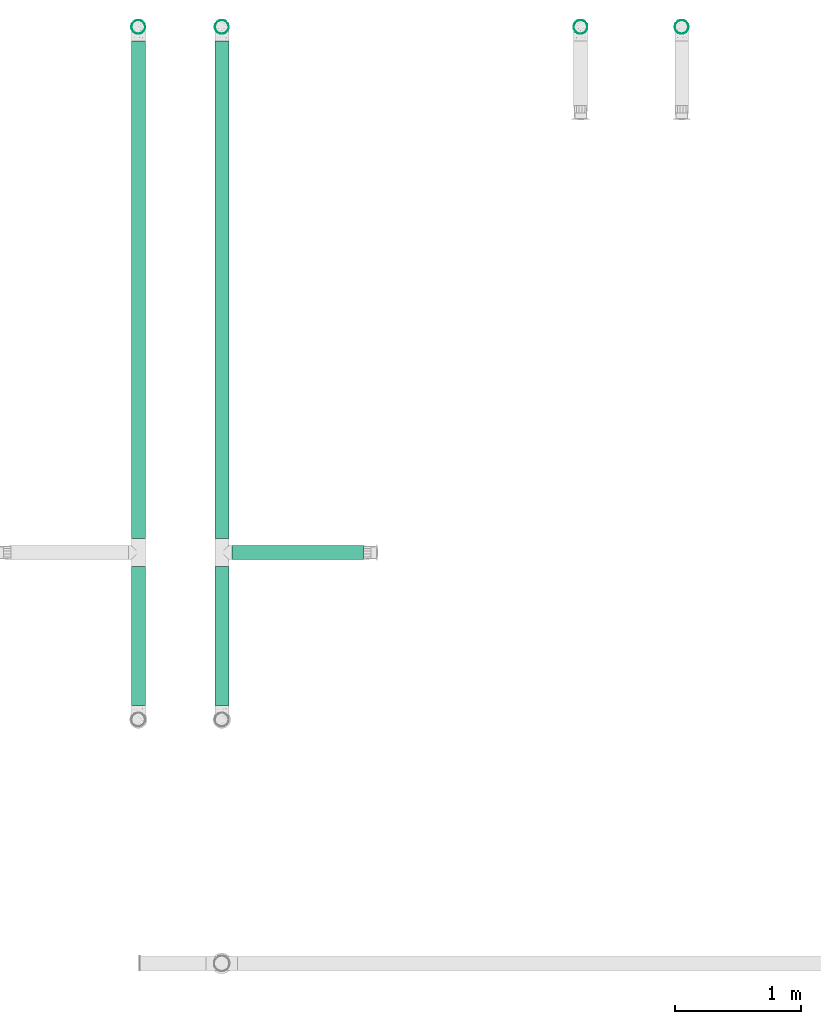
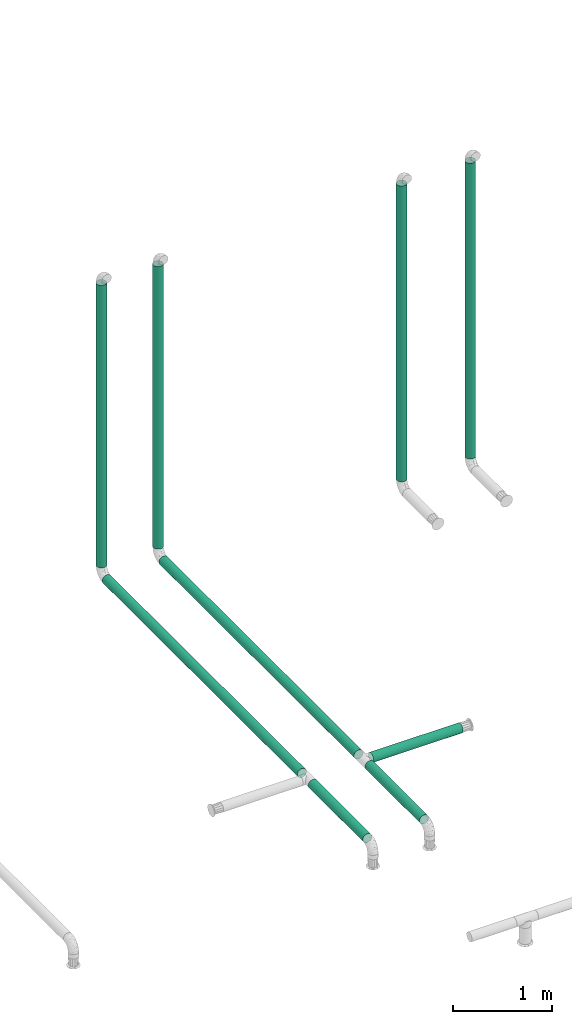
# One storey, part 4 of 115: 9 flow segments.
"""IFC2X3 building model written with IfcOpenShell, lengths in millimetres."""

from ifc_helpers import new_model, entity, si_unit, converted_unit, derived_unit, direction, frame, origin_with_axes, origin_2d_with_axis, place, context, subcontext, project, spatial, hollow_circle, extrude, source, transform, mapped, material, layer, layer_set, layer_usage, type_object, element, save


model = new_model("IFC2X3")

# Units and contexts
model_context = context("Model", 3, precision=1e-05, world=origin_with_axes(), true_north=direction((0.0, 1.0)))
body_context = subcontext(model_context, "Body", "Model", "MODEL_VIEW")
ifc_project = project(units=[si_unit("AREAUNIT", "SQUARE_METRE"), si_unit("VOLUMEUNIT", "CUBIC_METRE", prefix="DECI"), si_unit("TIMEUNIT", "SECOND"), si_unit("THERMODYNAMICTEMPERATUREUNIT", "DEGREE_CELSIUS"), si_unit("PRESSUREUNIT", "PASCAL"), si_unit("MASSUNIT", "GRAM", prefix="KILO"), si_unit("LENGTHUNIT", "METRE", prefix="MILLI"), si_unit("POWERUNIT", "WATT"), si_unit("ELECTRICCURRENTUNIT", "AMPERE"), si_unit("ELECTRICVOLTAGEUNIT", "VOLT"), derived_unit("VOLUMETRICFLOWRATEUNIT", [(si_unit("VOLUMEUNIT", "CUBIC_METRE", prefix="DECI"), 1), (si_unit("TIMEUNIT", "SECOND"), -1)]), derived_unit("LINEARVELOCITYUNIT", [(si_unit("LENGTHUNIT", "METRE"), 1), (si_unit("TIMEUNIT", "SECOND"), -1)]), derived_unit("MASSDENSITYUNIT", [(si_unit("MASSUNIT", "GRAM", prefix="KILO"), 1), (si_unit("VOLUMEUNIT", "CUBIC_METRE"), -1)]), converted_unit("PLANEANGLEUNIT", "DEGREE", entity("IfcRatioMeasure", 0.01745), si_unit("PLANEANGLEUNIT", "RADIAN"), dimensions=[0, 0, 0, 0, 0, 0, 0])], contexts=[model_context])

# Site, building, storey
site_placement = place(None, origin_with_axes())
site = spatial("IfcSite", under=ifc_project, at=site_placement, CompositionType="ELEMENT")
building_placement = place(site_placement, origin_with_axes())
building = spatial("IfcBuilding", under=site, at=building_placement, Name="mc-building", CompositionType="ELEMENT")
storey_placement = place(building_placement, frame((0.0, 0.0, 2950.0), z_axis=(0.0, 0.0, 1.0), x_axis=(1.0, 0.0, 0.0)))
storey = spatial("IfcBuildingStorey", under=building, at=storey_placement, Name="2. Korrus", CompositionType="ELEMENT", Elevation=2950.0)

# Flow segments
ifc_material = material(Name="FZ1")
ifc_layer = layer(ifc_material, 0.0)
ifc_layer_set = layer_set([ifc_layer], Name="FZ1")
ifc_layer_usage = layer_usage(ifc_layer_set, "AXIS1", "POSITIVE", 0.0)
duct_segment_type = type_object("IfcDuctSegmentType", PredefinedType="RIGIDSEGMENT")
shared_shape_1 = source(origin_with_axes(), body_context, "Body", "SweptSolid", [
    extrude(hollow_circle(Radius=55.0, WallThickness=2.0, at=origin_2d_with_axis()), frame((0.0, 0.0, 0.0), z_axis=(1.0, 0.0, 0.0), x_axis=(0.0, 1.0, 0.0)), (0.0, 0.0, 1.0), 3480.0),
])
for number, where, z_axis, x_axis in (
    (1, (11458.64544, 13663.57591, 2575.0), (1.0, 0.0, 0.0), (0.0, 0.0, 1.0)),
    (2, (12119.2372, 13663.57591, 2575.0), (-1.0, 0.0, 0.0), (0.0, 0.0, 1.0)),
):
    element("IfcFlowSegment", number, at=place(storey_placement, frame(where, z_axis=z_axis, x_axis=x_axis)), inside=storey, type_object=duct_segment_type, material=ifc_layer_usage, context=body_context, shape_type="MappedRepresentation", body=[
        mapped(shared_shape_1, transform((0.0, 0.0, 0.0), scale=1.0)),
    ])
shared_shape_2 = source(origin_with_axes(), body_context, "Body", "SweptSolid", [
    extrude(hollow_circle(Radius=55.0, WallThickness=2.0, at=origin_2d_with_axis()), frame((0.0, 0.0, 0.0), z_axis=(1.0, 0.0, 0.0), x_axis=(0.0, 1.0, 0.0)), (0.0, 0.0, 1.0), 3645.0),
])
for number, where, z_axis, x_axis in (
    (3, (15757.14677, 13663.57591, 2410.0), (1.0, 0.0, 0.0), (0.0, 0.0, 1.0)),
    (4, (14957.14677, 13663.57591, 2410.0), (1.0, 0.0, 0.0), (0.0, 0.0, 1.0)),
):
    element("IfcFlowSegment", number, at=place(storey_placement, frame(where, z_axis=z_axis, x_axis=x_axis)), inside=storey, type_object=duct_segment_type, material=ifc_layer_usage, context=body_context, shape_type="MappedRepresentation", body=[
        mapped(shared_shape_2, transform((0.0, 0.0, 0.0), scale=1.0)),
    ])
shared_shape_3 = source(origin_with_axes(), body_context, "Body", "SweptSolid", [
    extrude(hollow_circle(Radius=55.0, WallThickness=2.0, at=origin_2d_with_axis()), frame((0.0, 0.0, 0.0), z_axis=(1.0, 0.0, 0.0), x_axis=(0.0, 1.0, 0.0)), (0.0, 0.0, 1.0), 1101.4),
])
for number, where, z_axis, x_axis in (
    (5, (11458.64544, 9395.0, 2465.0), (0.0, 0.0, 1.0), (0.0, -1.0, 0.0)),
    (6, (12119.2372, 9395.0, 2465.0), (0.0, 0.0, 1.0), (0.0, -1.0, 0.0)),
):
    element("IfcFlowSegment", number, at=place(storey_placement, frame(where, z_axis=z_axis, x_axis=x_axis)), inside=storey, type_object=duct_segment_type, material=ifc_layer_usage, context=body_context, shape_type="MappedRepresentation", body=[
        mapped(shared_shape_3, transform((0.0, 0.0, 0.0), scale=1.0)),
    ])
shared_shape_4 = source(origin_with_axes(), body_context, "Body", "SweptSolid", [
    extrude(hollow_circle(Radius=55.0, WallThickness=2.0, at=origin_2d_with_axis()), frame((0.0, 0.0, 0.0), z_axis=(1.0, 0.0, 0.0), x_axis=(0.0, 1.0, 0.0)), (0.0, 0.0, 1.0), 3938.6),
])
for number, where, z_axis, x_axis in (
    (7, (11458.64544, 13553.57591, 2465.0), (0.0, 0.0, 1.0), (0.0, -1.0, 0.0)),
    (8, (12119.2372, 13553.57591, 2465.0), (0.0, 0.0, 1.0), (0.0, -1.0, 0.0)),
):
    element("IfcFlowSegment", number, at=place(storey_placement, frame(where, z_axis=z_axis, x_axis=x_axis)), inside=storey, type_object=duct_segment_type, material=ifc_layer_usage, context=body_context, shape_type="MappedRepresentation", body=[
        mapped(shared_shape_4, transform((0.0, 0.0, 0.0), scale=1.0)),
    ])
shared_shape_5 = source(origin_with_axes(), body_context, "Body", "SweptSolid", [
    extrude(hollow_circle(Radius=55.0, WallThickness=2.0, at=origin_2d_with_axis()), frame((0.0, 0.0, 0.0), z_axis=(1.0, 0.0, 0.0), x_axis=(0.0, 1.0, 0.0)), (0.0, 0.0, 1.0), 1041.0),
])
flow_segment_placement = place(storey_placement, frame((12199.2372, 9505.0, 2465.0), z_axis=(0.0, 0.0, 1.0), x_axis=(1.0, 0.0, 0.0)))
element("IfcFlowSegment", 9, at=flow_segment_placement, inside=storey, type_object=duct_segment_type, material=ifc_layer_usage, context=body_context, shape_type="MappedRepresentation", body=[
    mapped(shared_shape_5, transform((0.0, 0.0, 0.0), scale=1.0)),
])

save(model, "model.ifc")
